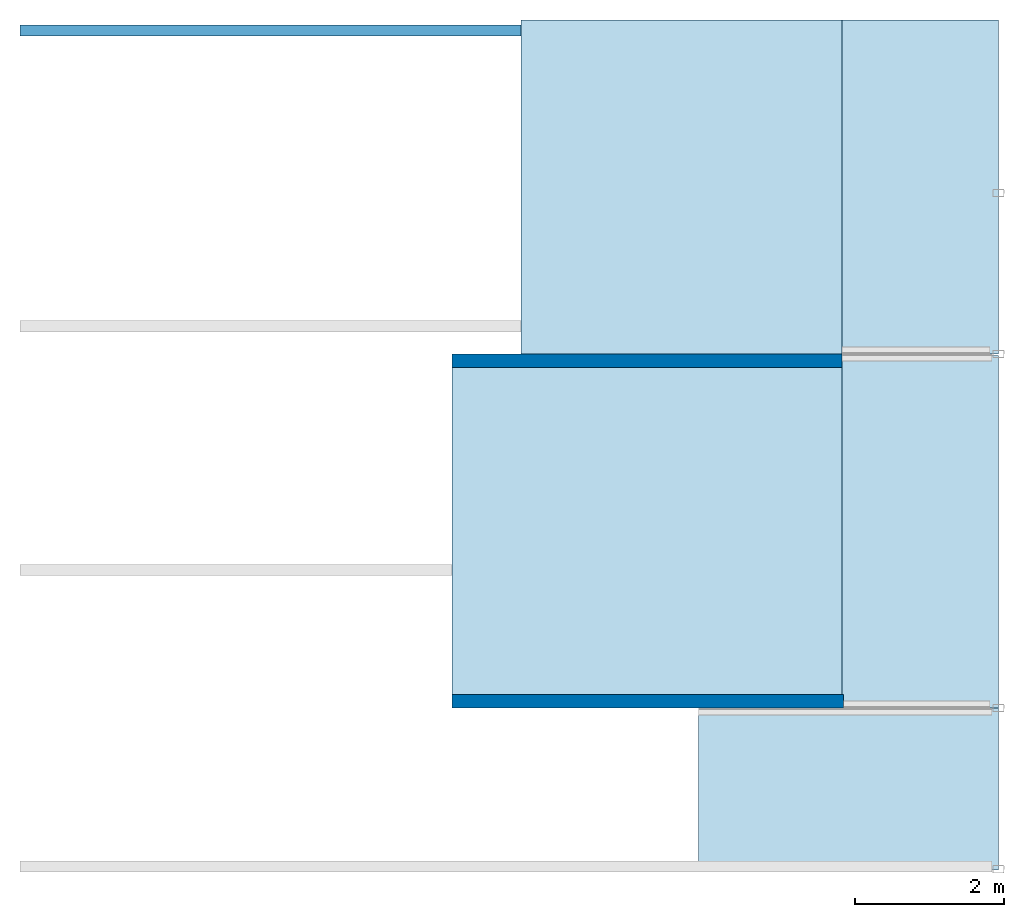
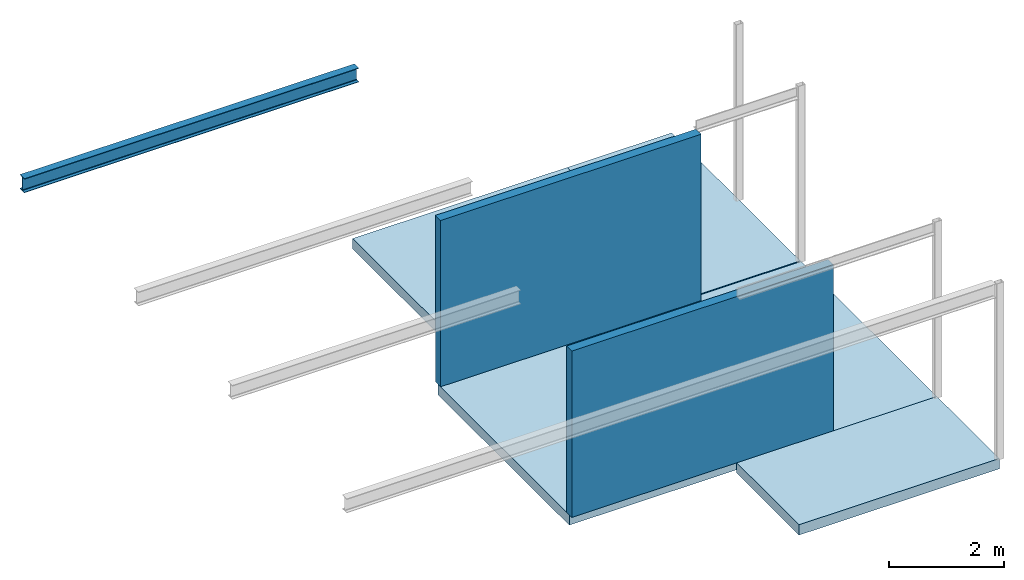
# One storey, part 2 of 2: 5 slabs, 2 walls, 1 beam.
"""IFC2X3 building model written with IfcOpenShell, lengths in millimetres."""

from ifc_helpers import new_model, entity, si_unit, converted_unit, frame, frame_2d, origin, place, context, project, spatial, polyline, circle_curve, parameter, trimmed, segment, composite_curve, rectangle, outline, extrude, clip, bounded_halfspace, material, layer, layer_set, layer_usage, element, save


model = new_model("IFC2X3")

# Units and contexts
model_context = context("Model", 3, precision=1e-06, world=origin())
plan_context = context("Plan", 3, precision=1e-06, world=origin())
ifc_project = project(units=[si_unit("LENGTHUNIT", "METRE", prefix="MILLI"), si_unit("AREAUNIT", "SQUARE_METRE", prefix="MILLI"), si_unit("VOLUMEUNIT", "CUBIC_METRE", prefix="MILLI"), converted_unit("PLANEANGLEUNIT", "DEGREE", entity("IfcRatioMeasure", 0.01745329251994328), si_unit("PLANEANGLEUNIT", "RADIAN"), dimensions=[0, 0, 0, 0, 0, 0, 0]), si_unit("TIMEUNIT", "SECOND")], contexts=[model_context, plan_context])

# Site, building, storey
site_placement = place(None, origin())
site = spatial("IfcSite", under=ifc_project, at=site_placement, CompositionType="ELEMENT")
building_placement = place(None, origin())
building = spatial("IfcBuilding", under=site, at=building_placement, CompositionType="ELEMENT")
storey_placement = place(building_placement, frame((0.0, 0.0, 7500.0)))
storey = spatial("IfcBuildingStorey", under=building, at=storey_placement, Name="Level 3", CompositionType="ELEMENT", Elevation=7500.000000000001)

# Beam
ifc_material_1 = material(Name="Metal - Steel - 345 MPa")
beam_placement = place(storey_placement, frame((-25022.42231700346, 11398.40101993982, 3750.0), z_axis=(0.0, 0.0, 1.0), x_axis=(0.0, -1.0, 0.0)))
element("IfcBeam", 1, at=beam_placement, inside=storey, material=ifc_material_1, Name="IPE-Beams:IPE300:IPE300", ObjectType="IPE-Beams:IPE300", context=model_context, shape_type="SweptSolid", body=[
    extrude(outline(composite_curve([segment(polyline([(-75.0, -139.3000000000008), (-75.0, -150.0)]), True, "CONTINUOUS"), segment(polyline([(-75.0, -150.0), (75.0, -150.0)]), True, "CONTINUOUS"), segment(polyline([(75.0, -150.0), (75.0, -139.3000000000008)]), True, "CONTINUOUS"), segment(polyline([(75.0, -139.3000000000008), (18.54999999999578, -139.3000000000008)]), True, "CONTINUOUS"), segment(trimmed(circle_curve(frame_2d((18.54999999999795, -124.2999999999999), x_axis=(1.0, 0.0)), 15.0), [parameter(180.0)], [parameter(269.9999999999996)], True, "PARAMETER"), False, "CONTINUOUS"), segment(polyline([(3.549999999997027, -124.2999999999999), (3.549999999997027, 124.2999999999999)]), True, "CONTINUOUS"), segment(trimmed(circle_curve(frame_2d((18.54999999999795, 124.2999999999999), x_axis=(1.0, 0.0)), 15.0), [parameter(90.00000000000009)], [parameter(180.0000000000002)], True, "PARAMETER"), False, "CONTINUOUS"), segment(polyline([(18.54999999999578, 139.2999999999987), (75.0, 139.2999999999987)]), True, "CONTINUOUS"), segment(polyline([(75.0, 139.2999999999987), (75.0, 150.0)]), True, "CONTINUOUS"), segment(polyline([(75.0, 150.0), (-75.0, 150.0)]), True, "CONTINUOUS"), segment(polyline([(-75.0, 150.0), (-75.0, 139.2999999999987)]), True, "CONTINUOUS"), segment(polyline([(-75.0, 139.2999999999987), (-18.55000000000445, 139.2999999999987)]), True, "CONTINUOUS"), segment(trimmed(circle_curve(frame_2d((-18.55000000000228, 124.2999999999999), x_axis=(1.0, 0.0)), 15.0), [parameter(359.9999999999996)], [parameter(89.99999999999973)], True, "PARAMETER"), False, "CONTINUOUS"), segment(polyline([(-3.550000000003525, 124.2999999999999), (-3.550000000003525, -124.2999999999999)]), True, "CONTINUOUS"), segment(trimmed(circle_curve(frame_2d((-18.55000000000228, -124.2999999999999), x_axis=(1.0, 0.0)), 15.0), [parameter(269.9999999999999)], [parameter(0.0)], True, "PARAMETER"), False, "CONTINUOUS"), segment(polyline([(-18.55000000000445, -139.3000000000008), (-75.0, -139.3000000000008)]), True, "CONTINUOUS")], self_intersect=False)), frame((0.0, -14.76091542191296, -150.0), z_axis=(0.0, -1.0, 0.0), x_axis=(1.0, 0.0, 0.0)), (0.0, 0.0, -1.0), 6714.999999999998),
])

# Slabs
ifc_material_2 = material(Name="Concrete - Cast In Situ")
ifc_layer_1 = layer(ifc_material_2, 220.0)
ifc_layer_set_1 = layer_set([ifc_layer_1], Name="Floor:Insitu Concrete 220mm")
ifc_layer_usage_1 = layer_usage(ifc_layer_set_1, "AXIS3", "POSITIVE", 0.0)
slab_1_placement = place(storey_placement, frame((-19247.18401022489, 2401.09876815164, -220.0)))
element("IfcSlab", 2, at=slab_1_placement, inside=storey, material=ifc_layer_usage_1, Name="Floor:Insitu Concrete 220mm", ObjectType="Floor:Insitu Concrete 220mm", PredefinedType="FLOOR", context=model_context, shape_type="SweptSolid", body=[
    extrude(rectangle(XDim=4570.000000000006, YDim=5250.000777799518, at=frame_2d((16622.18362132513, 4686.098768151644), x_axis=(0.0, -1.0))), frame((19247.18401022489, -2401.09876815164, 220.0), z_axis=(0.0, 0.0, -1.0), x_axis=(-1.0, 0.0, 0.0)), (0.0, 0.0, 1.0), 220.0),
])
ifc_layer_usage_2 = layer_usage(ifc_layer_set_1, "AXIS3", "POSITIVE", 0.0)
slab_2_placement = place(storey_placement, frame((-18322.18323242538, 6971.098768151646, -220.0)))
element("IfcSlab", 3, at=slab_2_placement, inside=storey, material=ifc_layer_usage_2, Name="Floor:Insitu Concrete 220mm", ObjectType="Floor:Insitu Concrete 220mm", PredefinedType="FLOOR", context=model_context, shape_type="SweptSolid", body=[
    extrude(rectangle(XDim=4567.302251788157, YDim=4310.557965402411, at=frame_2d((16166.90424972418, 9254.749894045724), x_axis=(0.0, -1.0))), frame((18322.18323242538, -6971.098768151646, 220.0), z_axis=(0.0, 0.0, -1.0), x_axis=(-1.0, 0.0, 0.0)), (0.0, 0.0, 1.0), 220.0),
])
ifc_layer_usage_3 = layer_usage(ifc_layer_set_1, "AXIS3", "POSITIVE", 0.0)
slab_3_placement = place(storey_placement, frame((-14011.62526702297, 7061.098768151647, -220.0)))
element("IfcSlab", 4, at=slab_3_placement, inside=storey, material=ifc_layer_usage_3, Name="Floor:Insitu Concrete 220mm", ObjectType="Floor:Insitu Concrete 220mm", PredefinedType="FLOOR", context=model_context, shape_type="SweptSolid", body=[
    extrude(rectangle(XDim=4477.302251788156, YDim=2094.442034597587, at=frame_2d((12964.40424972418, 9299.749894045726), x_axis=(0.0, -1.0))), frame((14011.62526702297, -7061.098768151647, 220.0), z_axis=(0.0, 0.0, -1.0), x_axis=(-1.0, 0.0, 0.0)), (0.0, 0.0, 1.0), 220.0),
])
ifc_layer_usage_4 = layer_usage(ifc_layer_set_1, "AXIS3", "POSITIVE", 0.0)
slab_4_placement = place(storey_placement, frame((-15937.18323242539, 142.3366320096107, -220.0)))
element("IfcSlab", 5, at=slab_4_placement, inside=storey, material=ifc_layer_usage_4, Name="Floor:Insitu Concrete 220mm", ObjectType="Floor:Insitu Concrete 220mm", PredefinedType="FLOOR", context=model_context, shape_type="SweptSolid", body=[
    extrude(rectangle(XDim=2168.762136142018, YDim=4019.999999999827, at=frame_2d((13927.18323242548, 1226.71770008062), x_axis=(0.0, -1.0))), frame((15937.18323242539, -142.3366320096107, 220.0), z_axis=(0.0, 0.0, -1.0), x_axis=(-1.0, 0.0, 0.0)), (0.0, 0.0, 1.0), 220.0),
])
ifc_layer_usage_5 = layer_usage(ifc_layer_set_1, "AXIS3", "POSITIVE", 0.0)
slab_5_placement = place(storey_placement, frame((-14011.62526702297, 2311.098768151617, -220.0)))
element("IfcSlab", 6, at=slab_5_placement, inside=storey, material=ifc_layer_usage_5, Name="Floor:Insitu Concrete 220mm", ObjectType="Floor:Insitu Concrete 220mm", PredefinedType="FLOOR", context=model_context, shape_type="SweptSolid", body=[
    extrude(rectangle(XDim=4728.20000000003, YDim=2094.442034597589, at=frame_2d((12964.40424972418, 4675.198768151632), x_axis=(0.0, -1.0))), frame((14011.62526702297, -2311.098768151617, 220.0), z_axis=(0.0, 0.0, -1.0), x_axis=(-1.0, 0.0, 0.0)), (0.0, 0.0, 1.0), 220.0),
])

# Walls
ifc_material_3 = material(Name="Default Wall")
ifc_layer_2 = layer(ifc_material_3, 180.0)
ifc_layer_set_2 = layer_set([ifc_layer_2], Name="Basic Wall:Generic - 180mm")
ifc_layer_usage_6 = layer_usage(ifc_layer_set_2, "AXIS2", "POSITIVE", -90.0)
wall_1_placement = place(storey_placement, frame((-19247.18401022489, 6971.098768151646, 0.0)))
element("IfcWallStandardCase", 7, at=wall_1_placement, inside=storey, material=ifc_layer_usage_6, Name="Basic Wall:Generic - 180mm", ObjectType="Basic Wall:Generic - 180mm", context=model_context, shape_type="Clipping", body=[
    clip(extrude(rectangle(XDim=5235.558743201926, YDim=180.0000000000002, at=frame_2d((2617.779371600963, 0.0), x_axis=(-1.0, 0.0))), origin(), (0.0, 0.0, 1.0), 3750.000000000001), bounded_halfspace(frame((0.0, -90.0, 3530.0), z_axis=(0.0, 0.0, 1.0), x_axis=(0.0, 1.0, 0.0)), False, frame((0.0, -90.0, 3530.0)), polyline([(0.0, 0.0), (5235.558743201926, 0.0), (5235.558743201926, 90.0), (5235.558743201925, 180.0), (0.0, 180.0), (0.0, 90.0), (0.0, 0.0)]))),
])
ifc_layer_usage_7 = layer_usage(ifc_layer_set_2, "AXIS2", "POSITIVE", -90.0)
wall_2_placement = place(storey_placement, frame((-13997.18323242538, 2401.098768151623, 0.0), z_axis=(0.0, 0.0, 1.0), x_axis=(-1.0, 0.0, 0.0)))
element("IfcWallStandardCase", 8, at=wall_2_placement, inside=storey, material=ifc_layer_usage_7, Name="Basic Wall:Generic - 180mm", ObjectType="Basic Wall:Generic - 180mm", context=model_context, shape_type="Clipping", body=[
    clip(clip(clip(extrude(rectangle(XDim=5250.000777799519, YDim=179.9999999999997, at=frame_2d((2625.000388899759, 0.0), x_axis=(-1.0, 0.0))), origin(), (0.0, 0.0, 1.0), 3750.000000000001), bounded_halfspace(frame((0.0, -90.0, 3530.0), z_axis=(0.0, 0.0, -1.0), x_axis=(0.0, 1.0, 0.0)), True, frame((0.0, -90.0, 3530.0)), polyline([(0.0, 0.0), (5250.000777799519, 0.0), (5250.000777799519, 90.0), (0.0, 90.0), (0.0, 0.0)]))), bounded_halfspace(frame((0.0, -90.0, 3530.0), z_axis=(0.0, 0.0, -1.0), x_axis=(0.0, 1.0, 0.0)), True, frame((0.0, -90.0, 3530.0)), polyline([(0.0, 0.0), (5250.000777799519, 0.0), (5250.000777799519, 90.0), (0.0, 90.0), (0.0, 0.0)]))), bounded_halfspace(frame((5250.000777799518, 0.0, 3530.0), z_axis=(0.0, 0.0, 1.0), x_axis=(0.0, 1.0, 0.0)), False, frame((5250.000777799518, 0.0, 3530.0)), polyline([(0.0, 0.0), (0.0, 90.0), (-5250.000777799519, 90.0), (-5250.000777799519, 0.0), (0.0, 0.0)]))),
])

save(model, "model.ifc")
